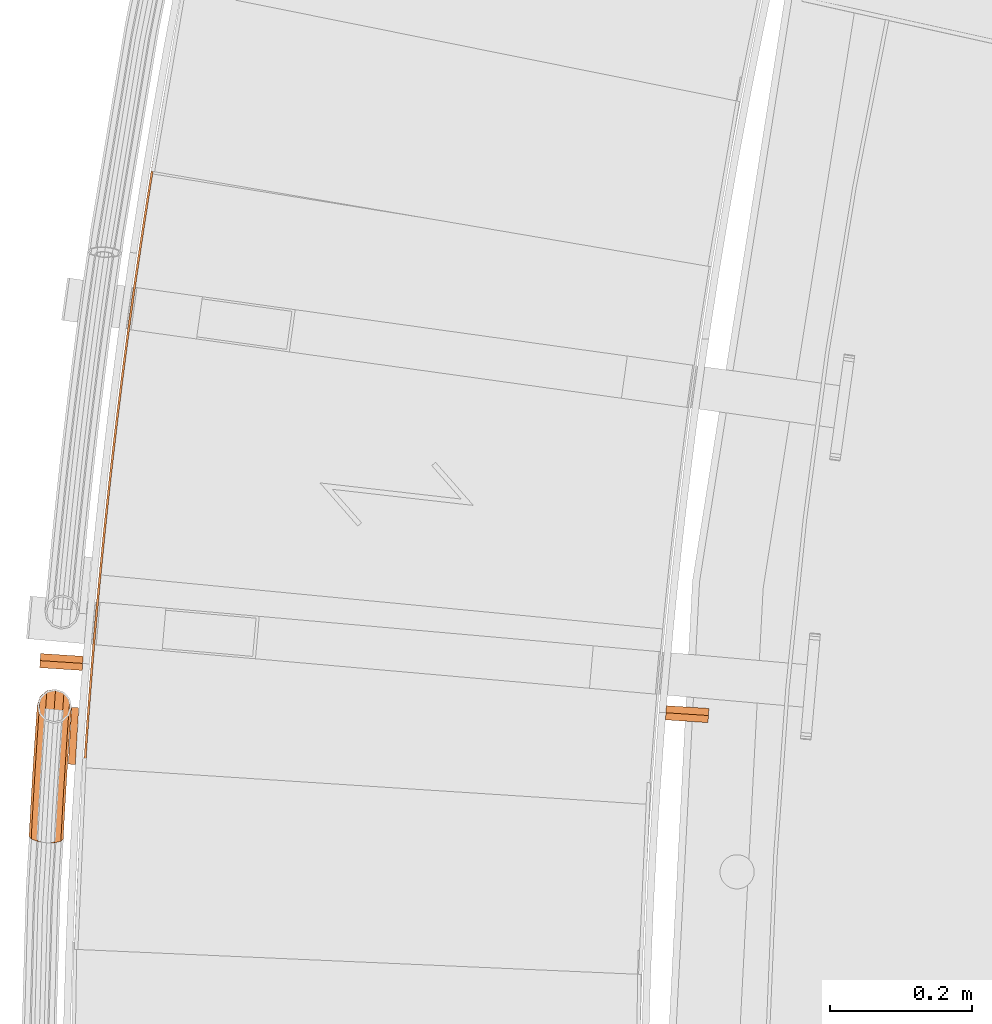
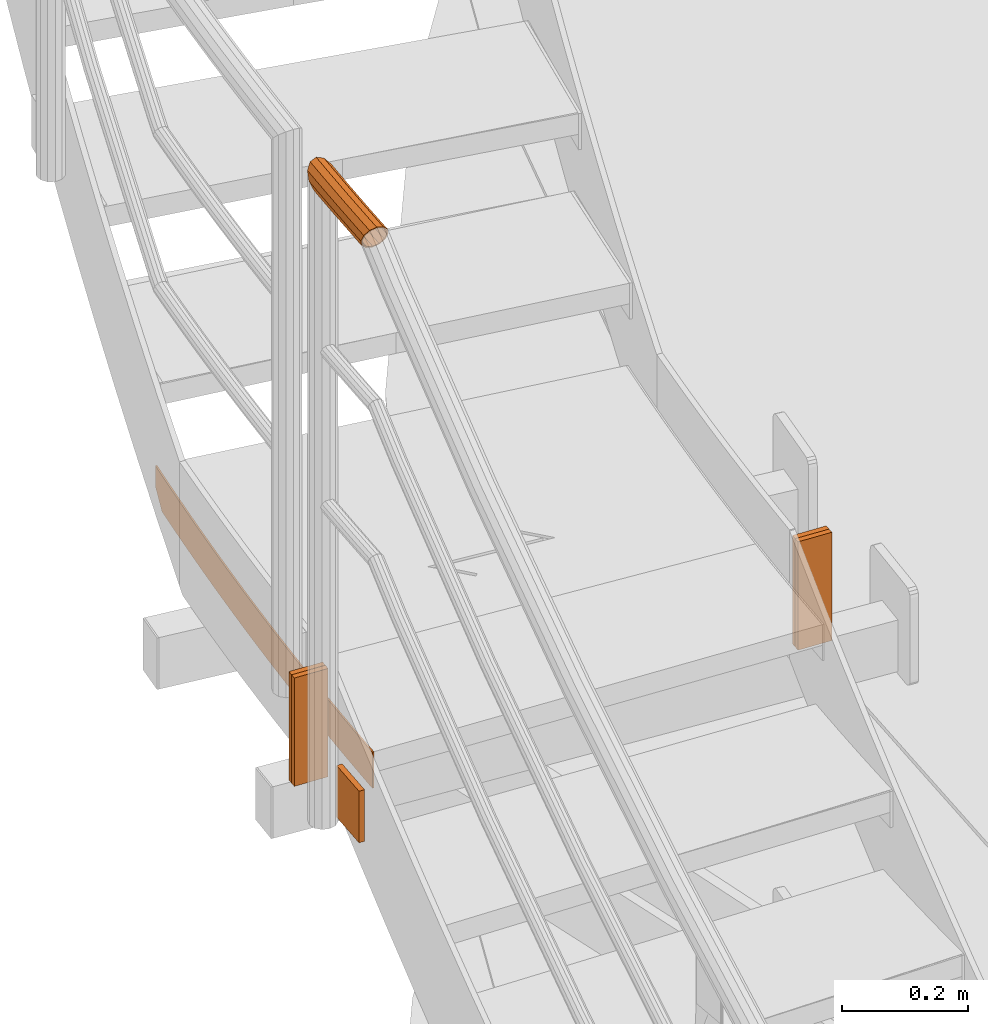
# One storey, part 56 of 126: 7 proxies.
"""IFC2X3 building model written with IfcOpenShell, lengths in millimetres."""

from ifc_helpers import new_model, si_unit, origin, origin_with_axes, place, context, project, spatial, faceted_brep, material, element, save


model = new_model("IFC2X3")

# Units and contexts
context_of_model_1 = context(None, 3, precision=0.1, world=origin())
context_of_model_2 = context(None, 3, precision=0.1, world=origin())
ifc_project = project(units=[si_unit("LENGTHUNIT", "METRE", prefix="MILLI"), si_unit("AREAUNIT", "SQUARE_METRE", prefix="CENTI"), si_unit("VOLUMEUNIT", "CUBIC_METRE", prefix="CENTI"), si_unit("MASSUNIT", "GRAM", prefix="KILO")], contexts=[context_of_model_1, context_of_model_2])

# Site, building, storey
site_placement = place(None, origin_with_axes())
site = spatial("IfcSite", under=ifc_project, at=site_placement, CompositionType="ELEMENT")
building_placement = place(site_placement, origin_with_axes())
building = spatial("IfcBuilding", under=site, at=building_placement, CompositionType="ELEMENT")
storey_placement = place(building_placement, origin_with_axes())
storey = spatial("IfcBuildingStorey", under=building, at=storey_placement, CompositionType="ELEMENT")

# Proxies
ifc_material = material(Name="S235JRG2")
proxy_1_placement = place(storey_placement, origin_with_axes())
element("IfcBuildingElementProxy", 1, at=proxy_1_placement, inside=storey, material=ifc_material, context=context_of_model_2, shape_type="Brep", body=[
    faceted_brep([(-793.4231, 8577.0492, 5472.55), (-790.4294, 8576.8545, 5472.55), (-790.4294, 8576.8545, 5542.55), (-793.4231, 8577.0492, 5542.55), (-792.8617, 8585.6834, 5472.55), (-789.8682, 8585.4859, 5472.55), (-789.8682, 8585.4859, 5542.55), (-792.8617, 8585.6834, 5542.55), (-791.705, 8602.9497, 5472.55), (-788.7119, 8602.7463, 5472.55), (-788.7119, 8602.7463, 5542.55), (-791.705, 8602.9497, 5542.55), (-790.5145, 8620.2137, 5472.55), (-787.5218, 8620.0044, 5472.55), (-787.5218, 8620.0044, 5542.55), (-790.5145, 8620.2137, 5542.55), (-789.29, 8637.4753, 5472.55), (-786.2978, 8637.2601, 5472.55), (-786.2978, 8637.2601, 5542.55), (-789.29, 8637.4753, 5542.55), (-788.0317, 8654.7345, 5472.55), (-785.0399, 8654.5134, 5472.55), (-785.0399, 8654.5134, 5542.55), (-788.0317, 8654.7345, 5542.55), (-786.7395, 8671.9912, 5472.55), (-783.7481, 8671.7642, 5472.55), (-783.7481, 8671.7642, 5542.55), (-786.7395, 8671.9912, 5542.55), (-785.4135, 8689.2453, 5472.55), (-782.4225, 8689.0125, 5472.55), (-782.4225, 8689.0125, 5542.55), (-785.4135, 8689.2453, 5542.55), (-784.0536, 8706.4968, 5472.55), (-781.0631, 8706.2581, 5472.55), (-781.0631, 8706.2581, 5542.55), (-784.0536, 8706.4968, 5542.55), (-782.6598, 8723.7455, 5472.55), (-779.6698, 8723.501, 5472.55), (-779.6698, 8723.501, 5542.55), (-782.6598, 8723.7455, 5542.55), (-781.2322, 8740.9916, 5472.55), (-778.2427, 8740.7411, 5472.55), (-778.2427, 8740.7411, 5542.55), (-781.2322, 8740.9916, 5542.55), (-779.7708, 8758.2347, 5472.55), (-776.7817, 8757.9784, 5472.55), (-776.7817, 8757.9784, 5542.55), (-779.7708, 8758.2347, 5542.55), (-778.2755, 8775.475, 5472.55), (-775.2869, 8775.2128, 5472.55), (-775.2869, 8775.2128, 5542.55), (-778.2755, 8775.475, 5542.55), (-776.7463, 8792.7123, 5472.55), (-773.7583, 8792.4443, 5472.55), (-773.7583, 8792.4443, 5542.55), (-776.7463, 8792.7123, 5542.55), (-775.1834, 8809.9465, 5472.55), (-772.1959, 8809.6727, 5472.55), (-772.1959, 8809.6727, 5542.55), (-775.1834, 8809.9465, 5542.55), (-773.5866, 8827.1777, 5472.55), (-770.5996, 8826.898, 5472.55), (-770.5996, 8826.898, 5542.55), (-773.5866, 8827.1777, 5542.55), (-771.956, 8844.4057, 5472.55), (-768.9696, 8844.1201, 5472.55), (-768.9696, 8844.1201, 5542.55), (-771.956, 8844.4057, 5542.55), (-770.2916, 8861.6305, 5472.55), (-767.3057, 8861.339, 5472.55), (-767.3057, 8861.339, 5542.55), (-770.2916, 8861.6305, 5542.55), (-768.5933, 8878.8519, 5472.55), (-765.6081, 8878.5546, 5472.55), (-765.6081, 8878.5546, 5542.55), (-768.5933, 8878.8519, 5542.55), (-766.8613, 8896.07, 5472.55), (-763.8767, 8895.7668, 5472.55), (-763.8767, 8895.7668, 5542.55), (-766.8613, 8896.07, 5542.55), (-765.0955, 8913.2847, 5472.55), (-762.1115, 8912.9756, 5472.55), (-762.1115, 8912.9756, 5542.55), (-765.0955, 8913.2847, 5542.55), (-763.2959, 8930.4958, 5472.55), (-760.3125, 8930.1809, 5472.55), (-760.3125, 8930.1809, 5542.55), (-763.2959, 8930.4958, 5542.55), (-761.4626, 8947.7034, 5472.55), (-758.4798, 8947.3827, 5472.55), (-758.4798, 8947.3827, 5542.55), (-761.4626, 8947.7034, 5542.55), (-759.5954, 8964.9074, 5472.55), (-756.6133, 8964.5808, 5472.55), (-756.6133, 8964.5808, 5542.55), (-759.5954, 8964.9074, 5542.55), (-757.6945, 8982.1077, 5472.55), (-754.713, 8981.7752, 5472.55), (-754.713, 8981.7752, 5542.55), (-757.6945, 8982.1077, 5542.55), (-755.7599, 8999.3042, 5472.55), (-752.779, 8998.9659, 5472.55), (-752.779, 8998.9659, 5542.55), (-755.7599, 8999.3042, 5542.55), (-753.7915, 9016.4968, 5472.55), (-750.8113, 9016.1527, 5472.55), (-750.8113, 9016.1527, 5542.55), (-753.7915, 9016.4968, 5542.55), (-751.7894, 9033.6856, 5472.55), (-748.8098, 9033.3356, 5472.55), (-748.8098, 9033.3356, 5542.55), (-751.7894, 9033.6856, 5542.55), (-749.7535, 9050.8704, 5472.55), (-746.7747, 9050.5146, 5472.55), (-746.7747, 9050.5146, 5542.55), (-749.7535, 9050.8704, 5542.55), (-747.6839, 9068.0512, 5472.55), (-744.7058, 9067.6895, 5472.55), (-744.7058, 9067.6895, 5542.55), (-747.6839, 9068.0512, 5542.55), (-745.5806, 9085.2279, 5472.55), (-742.6032, 9084.8604, 5472.55), (-742.6032, 9084.8604, 5542.55), (-745.5806, 9085.2279, 5542.55), (-743.4436, 9102.4005, 5472.55), (-740.4669, 9102.0271, 5472.55), (-740.4669, 9102.0271, 5542.55), (-743.4436, 9102.4005, 5542.55), (-741.2728, 9119.5688, 5472.55), (-738.2969, 9119.1895, 5472.55), (-738.2969, 9119.1895, 5542.55), (-741.2728, 9119.5688, 5542.55), (-739.0684, 9136.7328, 5472.55), (-736.0933, 9136.3477, 5472.55), (-736.0933, 9136.3477, 5542.55), (-739.0684, 9136.7328, 5542.55), (-736.8303, 9153.8924, 5472.55), (-733.8559, 9153.5015, 5472.55), (-733.8559, 9153.5015, 5542.55), (-736.8303, 9153.8924, 5542.55), (-734.5586, 9171.0476, 5472.55), (-731.5849, 9170.6509, 5472.55), (-731.5849, 9170.6509, 5542.55), (-734.5586, 9171.0476, 5542.55), (-732.2531, 9188.1984, 5472.55), (-729.2803, 9187.7958, 5472.55), (-729.2803, 9187.7958, 5542.55), (-732.2531, 9188.1984, 5542.55), (-729.9141, 9205.3445, 5472.55), (-726.942, 9204.9361, 5472.55), (-726.942, 9204.9361, 5542.55), (-729.9141, 9205.3445, 5542.55), (-727.5413, 9222.4861, 5472.55), (-724.57, 9222.0718, 5472.55), (-724.57, 9222.0718, 5542.55), (-727.5413, 9222.4861, 5542.55), (-725.1349, 9239.623, 5472.55), (-722.1645, 9239.2029, 5472.55), (-722.1645, 9239.2029, 5542.55), (-725.1349, 9239.623, 5542.55), (-722.6949, 9256.7551, 5472.55), (-719.7253, 9256.3291, 5472.55), (-719.7253, 9256.3291, 5542.55), (-722.6949, 9256.7551, 5542.55), (-720.2213, 9273.8823, 5472.55), (-717.2525, 9273.4506, 5472.55), (-717.2525, 9273.4506, 5542.55), (-720.2213, 9273.8823, 5542.55), (-717.7141, 9291.0047, 5472.55), (-714.7461, 9290.5672, 5472.55), (-714.7461, 9290.5672, 5542.55), (-717.7141, 9291.0047, 5542.55), (-715.1732, 9308.1222, 5472.55), (-712.2062, 9307.6788, 5472.55), (-712.2062, 9307.6788, 5542.55), (-715.1732, 9308.1222, 5542.55), (-712.5988, 9325.2346, 5472.55), (-709.6326, 9324.7854, 5472.55), (-709.6326, 9324.7854, 5542.55), (-712.5988, 9325.2346, 5542.55), (-709.9908, 9342.3419, 5472.55), (-707.0255, 9341.8869, 5472.55), (-707.0255, 9341.8869, 5542.55), (-709.9908, 9342.3419, 5542.55), (-707.3492, 9359.4441, 5472.55), (-704.3848, 9358.9833, 5472.55), (-704.3848, 9358.9833, 5542.55), (-707.3492, 9359.4441, 5542.55), (-704.674, 9376.5411, 5472.55), (-701.7106, 9376.0744, 5472.55), (-701.7106, 9376.0744, 5542.55), (-704.674, 9376.5411, 5542.55), (-701.9654, 9393.6328, 5472.55), (-699.0028, 9393.1603, 5472.55), (-699.0028, 9393.1603, 5542.55), (-701.9654, 9393.6328, 5542.55), (-699.8859, 9406.5893, 5472.55), (-696.8789, 9406.3938, 5472.55), (-696.2615, 9410.2408, 5476.4289), (-696.2615, 9410.2408, 5542.55), (-699.2231, 9410.7191, 5542.55), (-699.2231, 9410.7191, 5476.7141), (-693.4867, 9427.3159, 5493.6481), (-693.4867, 9427.3159, 5542.55), (-696.4473, 9427.8, 5542.55), (-696.4473, 9427.8, 5493.9391), (-692.0825, 9435.8507, 5502.256), (-692.0825, 9435.8507, 5542.55), (-695.0427, 9436.3377, 5542.55), (-695.0427, 9436.3377, 5502.55)], [[[0, 1, 2, 3]], [[0, 4, 5, 1]], [[1, 5, 6, 2]], [[2, 6, 7, 3]], [[3, 7, 4, 0]], [[4, 8, 9, 5]], [[5, 9, 10, 6]], [[6, 10, 11, 7]], [[7, 11, 8, 4]], [[8, 12, 13, 9]], [[9, 13, 14, 10]], [[10, 14, 15, 11]], [[11, 15, 12, 8]], [[12, 16, 17, 13]], [[13, 17, 18, 14]], [[14, 18, 19, 15]], [[15, 19, 16, 12]], [[16, 20, 21, 17]], [[17, 21, 22, 18]], [[18, 22, 23, 19]], [[19, 23, 20, 16]], [[20, 24, 25, 21]], [[21, 25, 26, 22]], [[22, 26, 27, 23]], [[23, 27, 24, 20]], [[24, 28, 29, 25]], [[25, 29, 30, 26]], [[26, 30, 31, 27]], [[27, 31, 28, 24]], [[28, 32, 33, 29]], [[29, 33, 34, 30]], [[30, 34, 35, 31]], [[31, 35, 32, 28]], [[32, 36, 37, 33]], [[33, 37, 38, 34]], [[34, 38, 39, 35]], [[35, 39, 36, 32]], [[36, 40, 41, 37]], [[37, 41, 42, 38]], [[38, 42, 43, 39]], [[39, 43, 40, 36]], [[40, 44, 45, 41]], [[41, 45, 46, 42]], [[42, 46, 47, 43]], [[43, 47, 44, 40]], [[44, 48, 49, 45]], [[45, 49, 50, 46]], [[46, 50, 51, 47]], [[47, 51, 48, 44]], [[48, 52, 53, 49]], [[49, 53, 54, 50]], [[50, 54, 55, 51]], [[51, 55, 52, 48]], [[52, 56, 57, 53]], [[53, 57, 58, 54]], [[54, 58, 59, 55]], [[55, 59, 56, 52]], [[56, 60, 61, 57]], [[57, 61, 62, 58]], [[58, 62, 63, 59]], [[59, 63, 60, 56]], [[60, 64, 65, 61]], [[61, 65, 66, 62]], [[62, 66, 67, 63]], [[63, 67, 64, 60]], [[64, 68, 69, 65]], [[65, 69, 70, 66]], [[66, 70, 71, 67]], [[67, 71, 68, 64]], [[68, 72, 73, 69]], [[69, 73, 74, 70]], [[70, 74, 75, 71]], [[71, 75, 72, 68]], [[72, 76, 77, 73]], [[73, 77, 78, 74]], [[74, 78, 79, 75]], [[75, 79, 76, 72]], [[76, 80, 81, 77]], [[77, 81, 82, 78]], [[78, 82, 83, 79]], [[79, 83, 80, 76]], [[80, 84, 85, 81]], [[81, 85, 86, 82]], [[82, 86, 87, 83]], [[83, 87, 84, 80]], [[84, 88, 89, 85]], [[85, 89, 90, 86]], [[86, 90, 91, 87]], [[87, 91, 88, 84]], [[88, 92, 93, 89]], [[89, 93, 94, 90]], [[90, 94, 95, 91]], [[91, 95, 92, 88]], [[92, 96, 97, 93]], [[93, 97, 98, 94]], [[94, 98, 99, 95]], [[95, 99, 96, 92]], [[96, 100, 101, 97]], [[97, 101, 102, 98]], [[98, 102, 103, 99]], [[99, 103, 100, 96]], [[100, 104, 105, 101]], [[101, 105, 106, 102]], [[102, 106, 107, 103]], [[103, 107, 104, 100]], [[104, 108, 109, 105]], [[105, 109, 110, 106]], [[106, 110, 111, 107]], [[107, 111, 108, 104]], [[108, 112, 113, 109]], [[109, 113, 114, 110]], [[110, 114, 115, 111]], [[111, 115, 112, 108]], [[112, 116, 117, 113]], [[113, 117, 118, 114]], [[114, 118, 119, 115]], [[115, 119, 116, 112]], [[116, 120, 121, 117]], [[117, 121, 122, 118]], [[118, 122, 123, 119]], [[119, 123, 120, 116]], [[120, 124, 125, 121]], [[121, 125, 126, 122]], [[122, 126, 127, 123]], [[123, 127, 124, 120]], [[124, 128, 129, 125]], [[125, 129, 130, 126]], [[126, 130, 131, 127]], [[127, 131, 128, 124]], [[128, 132, 133, 129]], [[129, 133, 134, 130]], [[130, 134, 135, 131]], [[131, 135, 132, 128]], [[132, 136, 137, 133]], [[133, 137, 138, 134]], [[134, 138, 139, 135]], [[135, 139, 136, 132]], [[136, 140, 141, 137]], [[137, 141, 142, 138]], [[138, 142, 143, 139]], [[139, 143, 140, 136]], [[140, 144, 145, 141]], [[141, 145, 146, 142]], [[142, 146, 147, 143]], [[143, 147, 144, 140]], [[144, 148, 149, 145]], [[145, 149, 150, 146]], [[146, 150, 151, 147]], [[147, 151, 148, 144]], [[148, 152, 153, 149]], [[149, 153, 154, 150]], [[150, 154, 155, 151]], [[151, 155, 152, 148]], [[152, 156, 157, 153]], [[153, 157, 158, 154]], [[154, 158, 159, 155]], [[155, 159, 156, 152]], [[156, 160, 161, 157]], [[157, 161, 162, 158]], [[158, 162, 163, 159]], [[159, 163, 160, 156]], [[160, 164, 165, 161]], [[161, 165, 166, 162]], [[162, 166, 167, 163]], [[163, 167, 164, 160]], [[164, 168, 169, 165]], [[165, 169, 170, 166]], [[166, 170, 171, 167]], [[167, 171, 168, 164]], [[168, 172, 173, 169]], [[169, 173, 174, 170]], [[170, 174, 175, 171]], [[171, 175, 172, 168]], [[172, 176, 177, 173]], [[173, 177, 178, 174]], [[174, 178, 179, 175]], [[175, 179, 176, 172]], [[176, 180, 181, 177]], [[177, 181, 182, 178]], [[178, 182, 183, 179]], [[179, 183, 180, 176]], [[180, 184, 185, 181]], [[181, 185, 186, 182]], [[182, 186, 187, 183]], [[183, 187, 184, 180]], [[184, 188, 189, 185]], [[185, 189, 190, 186]], [[186, 190, 191, 187]], [[187, 191, 188, 184]], [[188, 192, 193, 189]], [[189, 193, 194, 190]], [[190, 194, 195, 191]], [[191, 195, 192, 188]], [[192, 196, 197, 193]], [[193, 197, 198, 199, 194]], [[194, 199, 200, 195]], [[192, 195, 200, 201, 196]], [[198, 202, 203, 199]], [[199, 203, 204, 200]], [[200, 204, 205, 201]], [[203, 202, 206, 207]], [[203, 207, 208, 204]], [[204, 208, 209, 205]], [[207, 206, 209, 208]], [[196, 201, 205, 209, 206, 202, 198, 197]]]),
])
proxy_2_placement = place(storey_placement, origin_with_axes())
element("IfcBuildingElementProxy", 2, at=proxy_2_placement, inside=storey, material=ifc_material, context=context_of_model_2, shape_type="Brep", body=[
    faceted_brep([(-810.0749, 8661.8748, 5371.35), (-800.0931, 8661.2733, 5371.35), (-804.9057, 8581.4182, 5371.35), (-814.8875, 8582.0197, 5371.35), (-810.0749, 8661.8748, 5471.35), (-814.8875, 8582.0197, 5471.35), (-804.9057, 8581.4182, 5471.35), (-800.0931, 8661.2733, 5471.35)], [[[0, 1, 2, 3]], [[4, 5, 6, 7]], [[0, 4, 7, 1]], [[1, 7, 6, 2]], [[0, 3, 5, 4]], [[2, 6, 5, 3]]]),
])
proxy_3_placement = place(storey_placement, origin_with_axes())
element("IfcBuildingElementProxy", 3, at=proxy_3_placement, inside=storey, material=ifc_material, context=context_of_model_2, shape_type="Brep", body=[
    faceted_brep([(26.3847, 8654.2889, 5622.55), (27.0336, 8664.2679, 5622.55), (27.0336, 8664.2679, 5412.55), (26.3847, 8654.2889, 5412.55), (86.9071, 8660.375, 5622.55), (86.2583, 8650.3961, 5622.55), (86.2583, 8650.3961, 5412.55), (86.9071, 8660.375, 5412.55)], [[[0, 1, 2, 3]], [[4, 5, 6, 7]], [[0, 3, 6, 5]], [[1, 4, 7, 2]], [[0, 5, 4, 1]], [[2, 7, 6, 3]]]),
])
proxy_4_placement = place(storey_placement, origin_with_axes())
element("IfcBuildingElementProxy", 4, at=proxy_4_placement, inside=storey, material=ifc_material, context=context_of_model_2, shape_type="Brep", body=[
    faceted_brep([(25.7359, 8644.31, 5622.55), (26.3847, 8654.2889, 5622.55), (26.3847, 8654.2889, 5412.55), (25.7359, 8644.31, 5412.55), (86.2583, 8650.3961, 5622.55), (85.6095, 8640.4172, 5622.55), (85.6095, 8640.4172, 5412.55), (86.2583, 8650.3961, 5412.55)], [[[0, 1, 2, 3]], [[4, 5, 6, 7]], [[0, 3, 6, 5]], [[1, 4, 7, 2]], [[0, 5, 4, 1]], [[2, 7, 6, 3]]]),
])
proxy_5_placement = place(storey_placement, origin_with_axes())
element("IfcBuildingElementProxy", 5, at=proxy_5_placement, inside=storey, material=ifc_material, context=context_of_model_2, shape_type="Brep", body=[
    faceted_brep([(-853.8006, 8737.6797, 5412.55), (-854.4494, 8727.7007, 5412.55), (-854.4494, 8727.7007, 5622.55), (-853.8006, 8737.6797, 5622.55), (-794.5758, 8723.8079, 5412.55), (-793.927, 8733.7868, 5412.55), (-793.927, 8733.7868, 5622.55), (-794.5758, 8723.8079, 5622.55)], [[[0, 1, 2, 3]], [[4, 5, 6, 7]], [[1, 4, 7, 2]], [[0, 3, 6, 5]], [[0, 5, 4, 1]], [[2, 7, 6, 3]]]),
])
proxy_6_placement = place(storey_placement, origin_with_axes())
element("IfcBuildingElementProxy", 6, at=proxy_6_placement, inside=storey, material=ifc_material, context=context_of_model_2, shape_type="Brep", body=[
    faceted_brep([(-854.4494, 8727.7007, 5412.55), (-855.0982, 8717.7218, 5412.55), (-855.0982, 8717.7218, 5622.55), (-854.4494, 8727.7007, 5622.55), (-795.2246, 8713.829, 5412.55), (-794.5758, 8723.8079, 5412.55), (-794.5758, 8723.8079, 5622.55), (-795.2246, 8713.829, 5622.55)], [[[0, 1, 2, 3]], [[4, 5, 6, 7]], [[1, 4, 7, 2]], [[0, 3, 6, 5]], [[0, 5, 4, 1]], [[2, 7, 6, 3]]]),
])
proxy_7_placement = place(storey_placement, origin_with_axes())
element("IfcBuildingElementProxy", 7, at=proxy_7_placement, inside=storey, material=ifc_material, Name="HANDLAUF", context=context_of_model_2, shape_type="Brep", body=[
    faceted_brep([(-821.2457, 8677.87, 6639.3145), (-816.1999, 8677.4935, 6634.2548), (-820.8515, 8683.0307, 6639.3145), (-832.6257, 8687.4293, 6642.55), (-833.2872, 8678.7686, 6642.55), (-844.8929, 8685.3743, 6639.3145), (-845.3287, 8679.6672, 6639.3145), (-851.1678, 8680.1029, 6633.4592), (-844.0822, 8679.5742, 6637.1494), (-847.6831, 8679.8429, 6633.5385), (-843.8134, 8683.0937, 6637.1494), (-832.8162, 8684.936, 6640.05), (-833.2872, 8678.7686, 6640.05), (-822.2608, 8680.9928, 6637.1494), (-822.4922, 8677.9631, 6637.1494), (-819.53, 8677.742, 6634.179), (-859.6251, 8649.6223, 6618.4), (-858.4548, 8665.6827, 6618.4), (-856.1114, 8653.322, 6606.325), (-856.3977, 8649.3928, 6606.325), (-852.5694, 8649.1205, 6602.487), (-814.674, 8646.4256, 6606.325), (-817.5866, 8646.6328, 6603.4051), (-814.4673, 8649.2625, 6606.325), (-810.3683, 8660.9951, 6618.4), (-811.4467, 8646.1961, 6618.4), (-812.7117, 8673.3558, 6630.475), (-814.674, 8646.4256, 6630.475), (-823.4913, 8647.0527, 6639.3145), (-835.5359, 8647.9092, 6642.55), (-847.5805, 8648.7657, 6639.3145), (-854.3558, 8677.4153, 6630.475), (-856.3977, 8649.3928, 6630.475), (-857.1314, 8649.4449, 6618.4), (-855.9658, 8665.44, 6618.4), (-852.2912, 8675.9581, 6629.225), (-854.2381, 8649.2392, 6629.225), (-846.3336, 8648.6771, 6637.1494), (-835.5359, 8647.9092, 6640.05), (-824.7381, 8647.1413, 6637.1494), (-814.958, 8672.3189, 6629.225), (-816.8336, 8646.5792, 6629.225), (-812.8572, 8661.2378, 6618.4), (-813.9404, 8646.3735, 6618.4), (-816.5319, 8650.7197, 6607.575), (-816.8336, 8646.5792, 6607.575), (-821.0846, 8646.8815, 6603.3133), (-854.2381, 8649.2392, 6607.575), (-849.2498, 8648.8845, 6602.5741), (-853.8651, 8654.3589, 6607.575), (-858.5437, 8618.4529, 6606.325), (-861.7718, 8618.6711, 6618.4), (-847.9357, 8643.6436, 6597.4855), (-849.7243, 8617.8566, 6597.4855), (-836.137, 8639.2426, 6594.25), (-837.6768, 8617.0421, 6594.25), (-823.8903, 8641.2996, 6597.4855), (-825.6293, 8616.2277, 6597.4855), (-816.8099, 8615.6314, 6606.325), (-813.5818, 8615.4132, 6618.4), (-816.8099, 8615.6314, 6630.475), (-825.6293, 8616.2277, 6639.3145), (-837.6768, 8617.0421, 6642.55), (-849.7243, 8617.8566, 6639.3145), (-858.5437, 8618.4529, 6630.475), (-856.3836, 8618.3068, 6629.225), (-859.2775, 8618.5025, 6618.4), (-848.4772, 8617.7723, 6637.1494), (-837.6768, 8617.0421, 6640.05), (-826.8764, 8616.312, 6637.1494), (-818.97, 8615.7774, 6629.225), (-816.0761, 8615.5818, 6618.4), (-818.97, 8615.7774, 6607.575), (-824.985, 8643.5817, 6599.6506), (-826.8764, 8616.312, 6599.6506), (-835.9639, 8641.7376, 6596.75), (-837.6768, 8617.0421, 6596.75), (-846.5413, 8645.683, 6599.6506), (-848.4772, 8617.7723, 6599.6506), (-856.3836, 8618.3068, 6607.575), (-860.5817, 8587.5057, 6606.325), (-863.8105, 8587.7126, 6618.4), (-851.7603, 8586.9402, 6597.4855), (-839.71, 8586.1678, 6594.25), (-827.6597, 8585.3954, 6597.4855), (-818.8383, 8584.8299, 6606.325), (-815.6094, 8584.6229, 6618.4), (-818.8383, 8584.8299, 6630.475), (-827.6597, 8585.3954, 6639.3145), (-839.71, 8586.1678, 6642.55), (-851.7603, 8586.9402, 6639.3145), (-860.5817, 8587.5057, 6630.475), (-858.421, 8587.3672, 6629.225), (-861.3157, 8587.5527, 6618.4), (-850.5128, 8586.8603, 6637.1494), (-839.71, 8586.1678, 6640.05), (-828.9071, 8585.4753, 6637.1494), (-820.9989, 8584.9684, 6629.225), (-818.1043, 8584.7829, 6618.4), (-820.9989, 8584.9684, 6607.575), (-828.9071, 8585.4753, 6599.6506), (-839.71, 8586.1678, 6596.75), (-850.5128, 8586.8603, 6599.6506), (-858.421, 8587.3672, 6607.575), (-862.5116, 8556.5515, 6606.325), (-865.7412, 8556.7472, 6618.4), (-853.6883, 8556.0169, 6597.4855), (-841.6354, 8555.2865, 6594.25), (-829.5824, 8554.5562, 6597.4855), (-820.7591, 8554.0215, 6606.325), (-817.5295, 8553.8258, 6618.4), (-820.7591, 8554.0215, 6630.475), (-829.5824, 8554.5562, 6639.3145), (-841.6354, 8555.2865, 6642.55), (-853.6883, 8556.0169, 6639.3145), (-862.5116, 8556.5515, 6630.475), (-860.3505, 8556.4206, 6629.225), (-863.2457, 8556.596, 6618.4), (-852.4406, 8555.9413, 6637.1494), (-841.6354, 8555.2865, 6640.05), (-830.8302, 8554.6318, 6637.1494), (-822.9202, 8554.1525, 6629.225), (-820.025, 8553.977, 6618.4), (-822.9202, 8554.1525, 6607.575), (-830.8302, 8554.6318, 6599.6506), (-841.6354, 8555.2865, 6596.75), (-852.4406, 8555.9413, 6599.6506), (-860.3505, 8556.4206, 6607.575), (-864.3335, 8525.5909, 6606.325), (-867.5637, 8525.7753, 6618.4), (-855.5083, 8525.087, 6597.4855), (-843.4529, 8524.3987, 6594.25), (-831.3975, 8523.7104, 6597.4855), (-822.5724, 8523.2066, 6606.325), (-819.3422, 8523.0222, 6618.4), (-822.5724, 8523.2066, 6630.475), (-831.3975, 8523.7104, 6639.3145), (-843.4529, 8524.3987, 6642.55), (-855.5083, 8525.087, 6639.3145), (-864.3335, 8525.5909, 6630.475), (-862.1719, 8525.4675, 6629.225), (-865.0678, 8525.6328, 6618.4), (-854.2603, 8525.0158, 6637.1494), (-843.4529, 8524.3987, 6640.05), (-832.6455, 8523.7817, 6637.1494), (-824.7339, 8523.33, 6629.225), (-821.8381, 8523.1647, 6618.4), (-824.7339, 8523.33, 6607.575), (-832.6455, 8523.7817, 6599.6506), (-843.4529, 8524.3987, 6596.75), (-854.2603, 8525.0158, 6599.6506), (-862.1719, 8525.4675, 6607.575), (-866.0473, 8494.624, 6606.325), (-869.2781, 8494.7972, 6618.4), (-857.2204, 8494.151, 6597.4855), (-845.1627, 8493.5048, 6594.25), (-833.105, 8492.8586, 6597.4855), (-824.2781, 8492.3855, 6606.325), (-821.0473, 8492.2124, 6618.4), (-824.2781, 8492.3855, 6630.475), (-833.105, 8492.8586, 6639.3145), (-845.1627, 8493.5048, 6642.55), (-857.2204, 8494.151, 6639.3145), (-866.0473, 8494.624, 6630.475), (-863.8853, 8494.5082, 6629.225), (-866.7817, 8494.6634, 6618.4), (-855.9722, 8494.0841, 6637.1494), (-845.1627, 8493.5048, 6640.05), (-834.3532, 8492.9255, 6637.1494), (-826.4401, 8492.5014, 6629.225), (-823.5437, 8492.3462, 6618.4), (-826.4401, 8492.5014, 6607.575), (-834.3532, 8492.9255, 6599.6506), (-845.1627, 8493.5048, 6596.75), (-855.9722, 8494.0841, 6599.6506), (-863.8853, 8494.5082, 6607.575), (-866.5806, 8484.3357, 6606.325), (-870.0047, 8480.781, 6618.4), (-857.6215, 8486.4139, 6597.4855), (-845.528, 8486.4586, 6594.25), (-833.5405, 8484.4578, 6597.4855), (-824.8711, 8480.9478, 6606.325), (-821.8427, 8476.8689, 6618.4), (-825.2668, 8473.3141, 6630.475), (-834.2259, 8471.236, 6639.3145), (-846.3194, 8471.1913, 6642.55), (-858.3069, 8473.1921, 6639.3145), (-866.9764, 8476.7021, 6630.475), (-864.797, 8476.9219, 6629.225), (-867.5119, 8480.5785, 6618.4), (-857.025, 8473.7752, 6637.1494), (-846.2785, 8471.9816, 6640.05), (-835.4369, 8472.0216, 6637.1494), (-827.4052, 8473.8846, 6629.225), (-824.3355, 8477.0714, 6618.4), (-827.0504, 8480.728, 6607.575), (-834.8224, 8483.8747, 6599.6506), (-845.5689, 8485.6683, 6596.75), (-856.4105, 8485.6283, 6599.6506), (-864.4422, 8483.7653, 6607.575)], [[[0, 1, 2]], [[0, 2, 3, 4]], [[4, 3, 5, 6]], [[6, 5, 7]], [[8, 9, 10]], [[8, 10, 11, 12]], [[12, 11, 13, 14]], [[14, 13, 15]], [[16, 17, 18, 19]], [[19, 18, 20]], [[21, 22, 23]], [[21, 23, 24, 25]], [[25, 24, 26, 27]], [[0, 28, 27, 26, 1]], [[0, 4, 29, 28]], [[4, 6, 30, 29]], [[31, 32, 30, 6, 7]], [[16, 32, 31, 17]], [[33, 34, 35, 36]], [[35, 9, 8, 37, 36]], [[8, 12, 38, 37]], [[12, 14, 39, 38]], [[14, 15, 40, 41, 39]], [[41, 40, 42, 43]], [[43, 42, 44, 45]], [[45, 44, 46]], [[47, 48, 49]], [[33, 47, 49, 34]], [[16, 19, 50, 51]], [[19, 20, 52, 53, 50]], [[53, 52, 54, 55]], [[55, 54, 56, 57]], [[56, 22, 21, 58, 57]], [[21, 25, 59, 58]], [[25, 27, 60, 59]], [[27, 28, 61, 60]], [[28, 29, 62, 61]], [[29, 30, 63, 62]], [[30, 32, 64, 63]], [[32, 16, 51, 64]], [[33, 36, 65, 66]], [[36, 37, 67, 65]], [[37, 38, 68, 67]], [[38, 39, 69, 68]], [[39, 41, 70, 69]], [[41, 43, 71, 70]], [[43, 45, 72, 71]], [[73, 74, 72, 45, 46]], [[74, 73, 75, 76]], [[76, 75, 77, 78]], [[47, 79, 78, 77, 48]], [[47, 33, 66, 79]], [[51, 50, 80, 81]], [[50, 53, 82, 80]], [[53, 55, 83, 82]], [[55, 57, 84, 83]], [[57, 58, 85, 84]], [[58, 59, 86, 85]], [[59, 60, 87, 86]], [[60, 61, 88, 87]], [[61, 62, 89, 88]], [[62, 63, 90, 89]], [[63, 64, 91, 90]], [[64, 51, 81, 91]], [[66, 65, 92, 93]], [[65, 67, 94, 92]], [[67, 68, 95, 94]], [[68, 69, 96, 95]], [[69, 70, 97, 96]], [[70, 71, 98, 97]], [[71, 72, 99, 98]], [[72, 74, 100, 99]], [[74, 76, 101, 100]], [[76, 78, 102, 101]], [[78, 79, 103, 102]], [[79, 66, 93, 103]], [[81, 80, 104, 105]], [[80, 82, 106, 104]], [[82, 83, 107, 106]], [[83, 84, 108, 107]], [[84, 85, 109, 108]], [[85, 86, 110, 109]], [[86, 87, 111, 110]], [[87, 88, 112, 111]], [[88, 89, 113, 112]], [[89, 90, 114, 113]], [[90, 91, 115, 114]], [[91, 81, 105, 115]], [[93, 92, 116, 117]], [[92, 94, 118, 116]], [[94, 95, 119, 118]], [[95, 96, 120, 119]], [[96, 97, 121, 120]], [[97, 98, 122, 121]], [[98, 99, 123, 122]], [[99, 100, 124, 123]], [[100, 101, 125, 124]], [[101, 102, 126, 125]], [[102, 103, 127, 126]], [[103, 93, 117, 127]], [[105, 104, 128, 129]], [[104, 106, 130, 128]], [[106, 107, 131, 130]], [[107, 108, 132, 131]], [[108, 109, 133, 132]], [[109, 110, 134, 133]], [[110, 111, 135, 134]], [[111, 112, 136, 135]], [[112, 113, 137, 136]], [[113, 114, 138, 137]], [[114, 115, 139, 138]], [[115, 105, 129, 139]], [[117, 116, 140, 141]], [[116, 118, 142, 140]], [[118, 119, 143, 142]], [[119, 120, 144, 143]], [[120, 121, 145, 144]], [[121, 122, 146, 145]], [[122, 123, 147, 146]], [[123, 124, 148, 147]], [[124, 125, 149, 148]], [[125, 126, 150, 149]], [[126, 127, 151, 150]], [[127, 117, 141, 151]], [[129, 128, 152, 153]], [[128, 130, 154, 152]], [[130, 131, 155, 154]], [[131, 132, 156, 155]], [[132, 133, 157, 156]], [[133, 134, 158, 157]], [[134, 135, 159, 158]], [[135, 136, 160, 159]], [[136, 137, 161, 160]], [[137, 138, 162, 161]], [[138, 139, 163, 162]], [[139, 129, 153, 163]], [[141, 140, 164, 165]], [[140, 142, 166, 164]], [[142, 143, 167, 166]], [[143, 144, 168, 167]], [[144, 145, 169, 168]], [[145, 146, 170, 169]], [[146, 147, 171, 170]], [[147, 148, 172, 171]], [[148, 149, 173, 172]], [[149, 150, 174, 173]], [[150, 151, 175, 174]], [[151, 141, 165, 175]], [[152, 176, 177, 153]], [[152, 154, 178, 176]], [[154, 155, 179, 178]], [[155, 156, 180, 179]], [[156, 157, 181, 180]], [[157, 158, 182, 181]], [[158, 159, 183, 182]], [[159, 160, 184, 183]], [[160, 161, 185, 184]], [[161, 162, 186, 185]], [[162, 163, 187, 186]], [[153, 177, 187, 163]], [[164, 188, 189, 165]], [[164, 166, 190, 188]], [[166, 167, 191, 190]], [[167, 168, 192, 191]], [[168, 169, 193, 192]], [[169, 170, 194, 193]], [[170, 171, 195, 194]], [[171, 172, 196, 195]], [[172, 173, 197, 196]], [[173, 174, 198, 197]], [[174, 175, 199, 198]], [[165, 189, 199, 175]], [[17, 31, 7, 5, 3, 2, 1, 26, 24, 23, 22, 56, 54, 52, 20, 18], [10, 9, 35, 34, 49, 48, 77, 75, 73, 46, 44, 42, 40, 15, 13, 11]], [[185, 186, 187, 177, 176, 178, 179, 180, 181, 182, 183, 184], [188, 190, 191, 192, 193, 194, 195, 196, 197, 198, 199, 189]]]),
])

save(model, "model.ifc")
